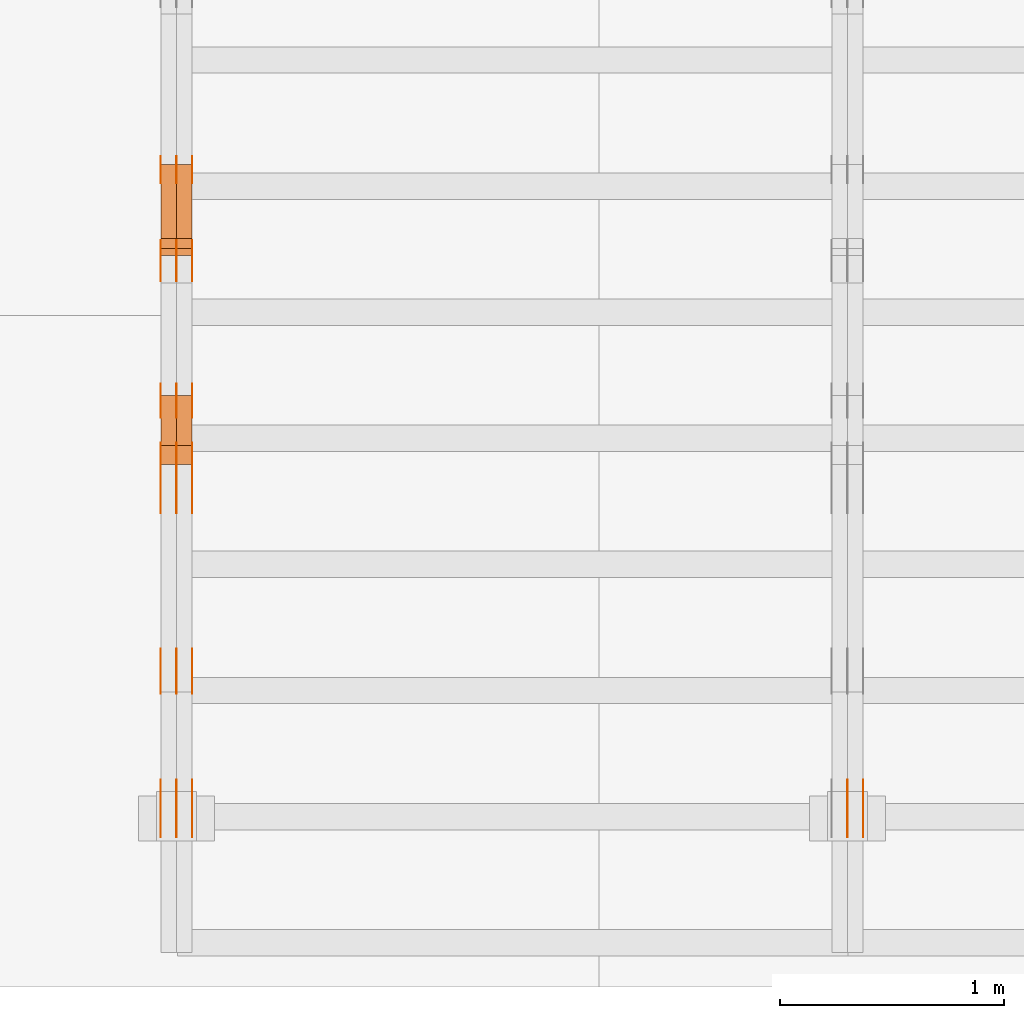
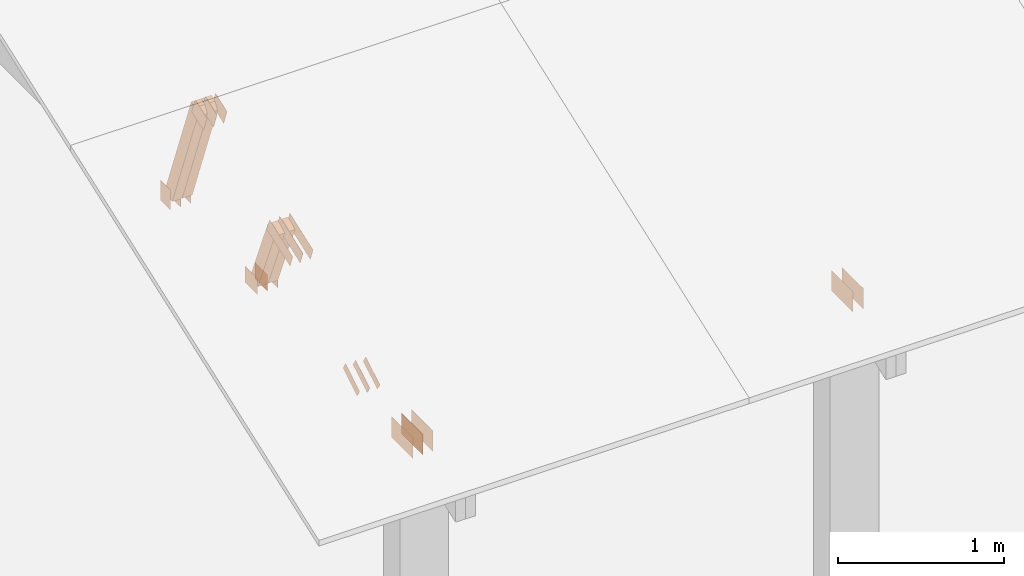
# One storey, part 67 of 189: 30 proxies.
"""IFC2X3 building model written with IfcOpenShell, lengths in millimetres."""

from ifc_helpers import new_model, entity, si_unit, converted_unit, derived_unit, direction, frame, frame_2d, origin, origin_2d_with_axis, place, context, subcontext, project, spatial, polyline, rectangle, outline, extrude, source, transform, mapped, material, type_object, type_shapes, element, save


model = new_model("IFC2X3")

# Units and contexts
model_context = context("Model", 3, precision=0.01, world=origin(), true_north=direction((6.12303176911189e-17, 1.0)))
body_context = subcontext(model_context, "Body", "Model", "MODEL_VIEW")
ifc_project = project(units=[si_unit("LENGTHUNIT", "METRE", prefix="MILLI"), si_unit("AREAUNIT", "SQUARE_METRE"), si_unit("VOLUMEUNIT", "CUBIC_METRE"), converted_unit("PLANEANGLEUNIT", "DEGREE", entity("IfcRatioMeasure", 0.0174532925199433), si_unit("PLANEANGLEUNIT", "RADIAN"), dimensions=[0, 0, 0, 0, 0, 0, 0]), si_unit("MASSUNIT", "GRAM", prefix="KILO"), derived_unit("MASSDENSITYUNIT", [(si_unit("MASSUNIT", "GRAM", prefix="KILO"), 1), (si_unit("LENGTHUNIT", "METRE"), -3)]), si_unit("TIMEUNIT", "SECOND"), si_unit("FREQUENCYUNIT", "HERTZ"), si_unit("THERMODYNAMICTEMPERATUREUNIT", "DEGREE_CELSIUS"), derived_unit("THERMALTRANSMITTANCEUNIT", [(si_unit("MASSUNIT", "GRAM", prefix="KILO"), 1), (si_unit("THERMODYNAMICTEMPERATUREUNIT", "KELVIN"), -1), (si_unit("TIMEUNIT", "SECOND"), -3)]), derived_unit("VOLUMETRICFLOWRATEUNIT", [(si_unit("LENGTHUNIT", "METRE"), 3), (si_unit("TIMEUNIT", "SECOND"), -1)]), si_unit("ELECTRICCURRENTUNIT", "AMPERE"), si_unit("ELECTRICVOLTAGEUNIT", "VOLT"), si_unit("POWERUNIT", "WATT"), si_unit("FORCEUNIT", "NEWTON"), si_unit("ILLUMINANCEUNIT", "LUX"), si_unit("LUMINOUSFLUXUNIT", "LUMEN"), si_unit("LUMINOUSINTENSITYUNIT", "CANDELA"), derived_unit("USERDEFINED", [(si_unit("MASSUNIT", "GRAM", prefix="KILO"), -1), (si_unit("LENGTHUNIT", "METRE"), -2), (si_unit("TIMEUNIT", "SECOND"), 3), (si_unit("LUMINOUSFLUXUNIT", "LUMEN"), 1)]), derived_unit("LINEARVELOCITYUNIT", [(si_unit("LENGTHUNIT", "METRE"), 1), (si_unit("TIMEUNIT", "SECOND"), -1)]), si_unit("PRESSUREUNIT", "PASCAL"), derived_unit("USERDEFINED", [(si_unit("LENGTHUNIT", "METRE"), -2), (si_unit("MASSUNIT", "GRAM", prefix="KILO"), 1), (si_unit("TIMEUNIT", "SECOND"), -2)])], contexts=[model_context])

# Site, building, storey
site_placement = place(None, origin())
site = spatial("IfcSite", under=ifc_project, at=site_placement, CompositionType="ELEMENT")
building_placement = place(site_placement, origin())
building = spatial("IfcBuilding", under=site, at=building_placement, CompositionType="ELEMENT")
storey_placement = place(building_placement, origin())
storey = spatial("IfcBuildingStorey", under=building, at=storey_placement, Name="Default", CompositionType="ELEMENT", Elevation=0.0)

# Proxies
ifc_material_1 = material(Name="IfcSurfaceStyle #22800")
building_element_proxy_type_1 = type_object("IfcBuildingElementProxyType", PredefinedType="NOTDEFINED", material=ifc_material_1)
shared_shape_1 = source(origin(), body_context, "Body", "SweptSolid", [
    extrude(rectangle(XDim=258.0, YDim=151.999992370605, at=origin_2d_with_axis()), frame((129.0, 76.0000049445079, 0.0), z_axis=(0.0, 0.0, 1.0), x_axis=(-1.0, 0.0, 0.0)), (0.0, 0.0, 1.0), 0.999999999999984),
])
type_shapes(building_element_proxy_type_1, [shared_shape_1])
proxy_1_placement = place(building_placement, frame((3336.0, 16.236328125, 268.138222870533), z_axis=(-1.0, 0.0, 0.0), x_axis=(0.0, 1.0, 0.0)))
element("IfcBuildingElementProxy", 1, at=proxy_1_placement, inside=storey, type_object=building_element_proxy_type_1, material=ifc_material_1, Name="GNT100S 152x258", context=body_context, shape_type="MappedRepresentation", body=[
    mapped(shared_shape_1, transform((0.0, 0.0, 0.0), scale=1.0)),
])
ifc_material_2 = material(Name="IfcSurfaceStyle #22743")
building_element_proxy_type_2 = type_object("IfcBuildingElementProxyType", PredefinedType="NOTDEFINED", material=ifc_material_2)
shared_shape_2 = source(origin(), body_context, "Body", "SweptSolid", [
    extrude(rectangle(XDim=258.0, YDim=151.999992370605, at=origin_2d_with_axis()), frame((129.0, 76.0000049445079, 0.0), z_axis=(0.0, 0.0, 1.0), x_axis=(-1.0, 0.0, 0.0)), (0.0, 0.0, 1.0), 0.999999999999984),
])
type_shapes(building_element_proxy_type_2, [shared_shape_2])
proxy_2_placement = place(building_placement, frame((3265.0, 16.236328125, 268.138222870533), z_axis=(-1.0, 0.0, 0.0), x_axis=(0.0, 1.0, 0.0)))
element("IfcBuildingElementProxy", 2, at=proxy_2_placement, inside=storey, type_object=building_element_proxy_type_2, material=ifc_material_2, Name="GNT100S 152x258", context=body_context, shape_type="MappedRepresentation", body=[
    mapped(shared_shape_2, transform((0.0, 0.0, 0.0), scale=1.0)),
])
ifc_material_3 = material(Name="IfcSurfaceStyle #10367")
building_element_proxy_type_3 = type_object("IfcBuildingElementProxyType", PredefinedType="NOTDEFINED", material=ifc_material_3)
shared_shape_3 = source(origin(), body_context, "Body", "SweptSolid", [
    extrude(rectangle(XDim=150.0, YDim=120.0, at=frame_2d((1.4210854715202e-14, -7.105427357601e-15), x_axis=(1.0, 0.0))), frame((75.0, 60.0004961323721, 0.0), z_axis=(0.0, 0.0, 1.0), x_axis=(-1.0, 0.0, 0.0)), (0.0, 0.0, 1.0), 1.3),
])
type_shapes(building_element_proxy_type_3, [shared_shape_3])
proxy_3_placement = place(building_placement, frame((336.3, 2940.99169136763, 170.0), z_axis=(-1.0, 0.0, 0.0), x_axis=(0.0, 0.0, 1.0)))
element("IfcBuildingElementProxy", 3, at=proxy_3_placement, inside=storey, type_object=building_element_proxy_type_3, material=ifc_material_3, context=body_context, shape_type="MappedRepresentation", body=[
    mapped(shared_shape_3, transform((0.0, 0.0, 0.0), scale=1.0)),
])
ifc_material_4 = material(Name="IfcSurfaceStyle #10310")
building_element_proxy_type_4 = type_object("IfcBuildingElementProxyType", PredefinedType="NOTDEFINED", material=ifc_material_4)
shared_shape_4 = source(origin(), body_context, "Body", "SweptSolid", [
    extrude(rectangle(XDim=150.0, YDim=120.0, at=frame_2d((1.4210854715202e-14, -7.105427357601e-15), x_axis=(1.0, 0.0))), frame((75.0, 60.0004961323721, 0.0), z_axis=(0.0, 0.0, 1.0), x_axis=(-1.0, 0.0, 0.0)), (0.0, 0.0, 1.0), 1.29999999999999),
])
type_shapes(building_element_proxy_type_4, [shared_shape_4])
proxy_4_placement = place(building_placement, frame((265.0, 2940.99169136763, 170.0), z_axis=(-1.0, 0.0, 0.0), x_axis=(0.0, 0.0, 1.0)))
element("IfcBuildingElementProxy", 4, at=proxy_4_placement, inside=storey, type_object=building_element_proxy_type_4, material=ifc_material_4, context=body_context, shape_type="MappedRepresentation", body=[
    mapped(shared_shape_4, transform((0.0, 0.0, 0.0), scale=1.0)),
])
ifc_material_5 = material(Name="IfcSurfaceStyle #10253")
building_element_proxy_type_5 = type_object("IfcBuildingElementProxyType", PredefinedType="NOTDEFINED", material=ifc_material_5)
shared_shape_5 = source(origin(), body_context, "Body", "SweptSolid", [
    extrude(rectangle(XDim=150.0, YDim=120.0, at=frame_2d((1.4210854715202e-14, -7.105427357601e-15), x_axis=(1.0, 0.0))), frame((75.0, 60.0004961323721, 0.0), z_axis=(0.0, 0.0, 1.0), x_axis=(-1.0, 0.0, 0.0)), (0.0, 0.0, 1.0), 1.29999999999999),
])
type_shapes(building_element_proxy_type_5, [shared_shape_5])
proxy_5_placement = place(building_placement, frame((266.3, 2940.99169136763, 170.0), z_axis=(-1.0, 0.0, 0.0), x_axis=(0.0, 0.0, 1.0)))
element("IfcBuildingElementProxy", 5, at=proxy_5_placement, inside=storey, type_object=building_element_proxy_type_5, material=ifc_material_5, context=body_context, shape_type="MappedRepresentation", body=[
    mapped(shared_shape_5, transform((0.0, 0.0, 0.0), scale=1.0)),
])
ifc_material_6 = material(Name="IfcSurfaceStyle #10196")
building_element_proxy_type_6 = type_object("IfcBuildingElementProxyType", PredefinedType="NOTDEFINED", material=ifc_material_6)
shared_shape_6 = source(origin(), body_context, "Body", "SweptSolid", [
    extrude(rectangle(XDim=150.0, YDim=120.0, at=frame_2d((1.4210854715202e-14, -7.105427357601e-15), x_axis=(1.0, 0.0))), frame((75.0, 60.0004961323721, 0.0), z_axis=(0.0, 0.0, 1.0), x_axis=(-1.0, 0.0, 0.0)), (0.0, 0.0, 1.0), 1.29999999999999),
])
type_shapes(building_element_proxy_type_6, [shared_shape_6])
proxy_6_placement = place(building_placement, frame((195.0, 2940.99169136763, 170.0), z_axis=(-1.0, 0.0, 0.0), x_axis=(0.0, 0.0, 1.0)))
element("IfcBuildingElementProxy", 6, at=proxy_6_placement, inside=storey, type_object=building_element_proxy_type_6, material=ifc_material_6, context=body_context, shape_type="MappedRepresentation", body=[
    mapped(shared_shape_6, transform((0.0, 0.0, 0.0), scale=1.0)),
])
ifc_material_7 = material(Name="IfcSurfaceStyle #10139")
building_element_proxy_type_7 = type_object("IfcBuildingElementProxyType", PredefinedType="NOTDEFINED", material=ifc_material_7)
shared_shape_7 = source(origin(), body_context, "Body", "SweptSolid", [
    extrude(outline(polyline([(-75.0008071857483, -59.9999039432187), (75.0002916555677, -59.9999039432187), (75.0008280609982, 59.9999039432187), (-75.0003125308176, 59.9999039432187), (-75.0008071857483, -59.9999039432187)])), frame((75.0008280609982, 60.0002349219685, 0.0), z_axis=(0.0, 0.0, 1.0), x_axis=(-1.0, 0.0, 0.0)), (0.0, 0.0, 1.0), 1.3),
])
type_shapes(building_element_proxy_type_7, [shared_shape_7])
proxy_7_placement = place(building_placement, frame((336.3, 2502.466796875, 1113.95080566406), z_axis=(-1.0, 0.0, 0.0), x_axis=(0.0, 0.939692620785908, 0.342020143325669)))
element("IfcBuildingElementProxy", 7, at=proxy_7_placement, inside=storey, type_object=building_element_proxy_type_7, material=ifc_material_7, context=body_context, shape_type="MappedRepresentation", body=[
    mapped(shared_shape_7, transform((0.0, 0.0, 0.0), scale=1.0)),
])
ifc_material_8 = material(Name="IfcSurfaceStyle #10082")
building_element_proxy_type_8 = type_object("IfcBuildingElementProxyType", PredefinedType="NOTDEFINED", material=ifc_material_8)
shared_shape_8 = source(origin(), body_context, "Body", "SweptSolid", [
    extrude(outline(polyline([(-75.0008071857483, -59.9999039432187), (75.0002916555677, -59.9999039432187), (75.0008280609982, 59.9999039432187), (-75.0003125308176, 59.9999039432187), (-75.0008071857483, -59.9999039432187)])), frame((75.0008280609982, 60.0002349219685, 0.0), z_axis=(0.0, 0.0, 1.0), x_axis=(-1.0, 0.0, 0.0)), (0.0, 0.0, 1.0), 1.29999999999999),
])
type_shapes(building_element_proxy_type_8, [shared_shape_8])
proxy_8_placement = place(building_placement, frame((265.0, 2502.466796875, 1113.95080566406), z_axis=(-1.0, 0.0, 0.0), x_axis=(0.0, 0.939692620785908, 0.342020143325669)))
element("IfcBuildingElementProxy", 8, at=proxy_8_placement, inside=storey, type_object=building_element_proxy_type_8, material=ifc_material_8, context=body_context, shape_type="MappedRepresentation", body=[
    mapped(shared_shape_8, transform((0.0, 0.0, 0.0), scale=1.0)),
])
ifc_material_9 = material(Name="IfcSurfaceStyle #10025")
building_element_proxy_type_9 = type_object("IfcBuildingElementProxyType", PredefinedType="NOTDEFINED", material=ifc_material_9)
shared_shape_9 = source(origin(), body_context, "Body", "SweptSolid", [
    extrude(outline(polyline([(-75.0008071857483, -59.9999039432187), (75.0002916555677, -59.9999039432187), (75.0008280609982, 59.9999039432187), (-75.0003125308176, 59.9999039432187), (-75.0008071857483, -59.9999039432187)])), frame((75.0008280609982, 60.0002349219685, 0.0), z_axis=(0.0, 0.0, 1.0), x_axis=(-1.0, 0.0, 0.0)), (0.0, 0.0, 1.0), 1.29999999999999),
])
type_shapes(building_element_proxy_type_9, [shared_shape_9])
proxy_9_placement = place(building_placement, frame((266.3, 2502.466796875, 1113.95080566406), z_axis=(-1.0, 0.0, 0.0), x_axis=(0.0, 0.939692620785908, 0.342020143325669)))
element("IfcBuildingElementProxy", 9, at=proxy_9_placement, inside=storey, type_object=building_element_proxy_type_9, material=ifc_material_9, context=body_context, shape_type="MappedRepresentation", body=[
    mapped(shared_shape_9, transform((0.0, 0.0, 0.0), scale=1.0)),
])
ifc_material_10 = material(Name="IfcSurfaceStyle #9968")
building_element_proxy_type_10 = type_object("IfcBuildingElementProxyType", PredefinedType="NOTDEFINED", material=ifc_material_10)
shared_shape_10 = source(origin(), body_context, "Body", "SweptSolid", [
    extrude(outline(polyline([(-75.0008071857483, -59.9999039432187), (75.0002916555677, -59.9999039432187), (75.0008280609982, 59.9999039432187), (-75.0003125308176, 59.9999039432187), (-75.0008071857483, -59.9999039432187)])), frame((75.0008280609982, 60.0002349219685, 0.0), z_axis=(0.0, 0.0, 1.0), x_axis=(-1.0, 0.0, 0.0)), (0.0, 0.0, 1.0), 1.29999999999999),
])
type_shapes(building_element_proxy_type_10, [shared_shape_10])
proxy_10_placement = place(building_placement, frame((195.0, 2502.466796875, 1113.95080566406), z_axis=(-1.0, 0.0, 0.0), x_axis=(0.0, 0.939692620785908, 0.342020143325669)))
element("IfcBuildingElementProxy", 10, at=proxy_10_placement, inside=storey, type_object=building_element_proxy_type_10, material=ifc_material_10, context=body_context, shape_type="MappedRepresentation", body=[
    mapped(shared_shape_10, transform((0.0, 0.0, 0.0), scale=1.0)),
])
ifc_material_11 = material(Name="IfcSurfaceStyle #9455")
building_element_proxy_type_11 = type_object("IfcBuildingElementProxyType", PredefinedType="NOTDEFINED", material=ifc_material_11)
shared_shape_11 = source(origin(), body_context, "Body", "SweptSolid", [
    extrude(rectangle(XDim=150.0, YDim=120.0, at=origin_2d_with_axis()), frame((75.0004757715869, 60.0, 0.0), z_axis=(0.0, 0.0, 1.0), x_axis=(-1.0, 0.0, 0.0)), (0.0, 0.0, 1.0), 1.3),
])
type_shapes(building_element_proxy_type_11, [shared_shape_11])
proxy_11_placement = place(building_placement, frame((336.3, 1892.68702422841, 305.0), z_axis=(-1.0, 0.0, 0.0), x_axis=(0.0, 1.0, 0.0)))
element("IfcBuildingElementProxy", 11, at=proxy_11_placement, inside=storey, type_object=building_element_proxy_type_11, material=ifc_material_11, context=body_context, shape_type="MappedRepresentation", body=[
    mapped(shared_shape_11, transform((0.0, 0.0, 0.0), scale=1.0)),
])
ifc_material_12 = material(Name="IfcSurfaceStyle #9398")
building_element_proxy_type_12 = type_object("IfcBuildingElementProxyType", PredefinedType="NOTDEFINED", material=ifc_material_12)
shared_shape_12 = source(origin(), body_context, "Body", "SweptSolid", [
    extrude(rectangle(XDim=150.0, YDim=120.0, at=origin_2d_with_axis()), frame((75.0004757715869, 60.0, 0.0), z_axis=(0.0, 0.0, 1.0), x_axis=(-1.0, 0.0, 0.0)), (0.0, 0.0, 1.0), 1.29999999999999),
])
type_shapes(building_element_proxy_type_12, [shared_shape_12])
proxy_12_placement = place(building_placement, frame((265.0, 1892.68702422841, 305.0), z_axis=(-1.0, 0.0, 0.0), x_axis=(0.0, 1.0, 0.0)))
element("IfcBuildingElementProxy", 12, at=proxy_12_placement, inside=storey, type_object=building_element_proxy_type_12, material=ifc_material_12, context=body_context, shape_type="MappedRepresentation", body=[
    mapped(shared_shape_12, transform((0.0, 0.0, 0.0), scale=1.0)),
])
ifc_material_13 = material(Name="IfcSurfaceStyle #9341")
building_element_proxy_type_13 = type_object("IfcBuildingElementProxyType", PredefinedType="NOTDEFINED", material=ifc_material_13)
shared_shape_13 = source(origin(), body_context, "Body", "SweptSolid", [
    extrude(rectangle(XDim=150.0, YDim=120.0, at=origin_2d_with_axis()), frame((75.0004757715869, 60.0, 0.0), z_axis=(0.0, 0.0, 1.0), x_axis=(-1.0, 0.0, 0.0)), (0.0, 0.0, 1.0), 1.29999999999999),
])
type_shapes(building_element_proxy_type_13, [shared_shape_13])
proxy_13_placement = place(building_placement, frame((266.3, 1892.68702422841, 305.0), z_axis=(-1.0, 0.0, 0.0), x_axis=(0.0, 1.0, 0.0)))
element("IfcBuildingElementProxy", 13, at=proxy_13_placement, inside=storey, type_object=building_element_proxy_type_13, material=ifc_material_13, context=body_context, shape_type="MappedRepresentation", body=[
    mapped(shared_shape_13, transform((0.0, 0.0, 0.0), scale=1.0)),
])
ifc_material_14 = material(Name="IfcSurfaceStyle #9284")
building_element_proxy_type_14 = type_object("IfcBuildingElementProxyType", PredefinedType="NOTDEFINED", material=ifc_material_14)
shared_shape_14 = source(origin(), body_context, "Body", "SweptSolid", [
    extrude(rectangle(XDim=150.0, YDim=120.0, at=origin_2d_with_axis()), frame((75.0004757715869, 60.0, 0.0), z_axis=(0.0, 0.0, 1.0), x_axis=(-1.0, 0.0, 0.0)), (0.0, 0.0, 1.0), 1.29999999999999),
])
type_shapes(building_element_proxy_type_14, [shared_shape_14])
proxy_14_placement = place(building_placement, frame((195.0, 1892.68702422841, 305.0), z_axis=(-1.0, 0.0, 0.0), x_axis=(0.0, 1.0, 0.0)))
element("IfcBuildingElementProxy", 14, at=proxy_14_placement, inside=storey, type_object=building_element_proxy_type_14, material=ifc_material_14, context=body_context, shape_type="MappedRepresentation", body=[
    mapped(shared_shape_14, transform((0.0, 0.0, 0.0), scale=1.0)),
])
ifc_material_15 = material(Name="IfcSurfaceStyle #9227")
building_element_proxy_type_15 = type_object("IfcBuildingElementProxyType", PredefinedType="NOTDEFINED", material=ifc_material_15)
shared_shape_15 = source(origin(), body_context, "Body", "SweptSolid", [
    extrude(outline(polyline([(-150.000217420008, -47.9999344162752), (150.000165800718, -47.9999344162752), (150.000227857633, 47.9999344162752), (-150.000176238343, 47.9999344162752), (-150.000217420008, -47.9999344162752)])), frame((150.000227857633, 48.0000430742566, 0.0), z_axis=(0.0, 0.0, 1.0), x_axis=(-1.0, 0.0, 0.0)), (0.0, 0.0, 1.0), 1.29999999999999),
])
type_shapes(building_element_proxy_type_15, [shared_shape_15])
proxy_15_placement = place(building_placement, frame((336.3, 1464.46484375, 723.378723144533), z_axis=(-1.0, 0.0, 0.0), x_axis=(0.0, 0.939692620785908, 0.342020143325669)))
element("IfcBuildingElementProxy", 15, at=proxy_15_placement, inside=storey, type_object=building_element_proxy_type_15, material=ifc_material_15, context=body_context, shape_type="MappedRepresentation", body=[
    mapped(shared_shape_15, transform((0.0, 0.0, 0.0), scale=1.0)),
])
ifc_material_16 = material(Name="IfcSurfaceStyle #9170")
building_element_proxy_type_16 = type_object("IfcBuildingElementProxyType", PredefinedType="NOTDEFINED", material=ifc_material_16)
shared_shape_16 = source(origin(), body_context, "Body", "SweptSolid", [
    extrude(outline(polyline([(-150.000217420008, -47.9999344162752), (150.000165800718, -47.9999344162752), (150.000227857633, 47.9999344162752), (-150.000176238343, 47.9999344162752), (-150.000217420008, -47.9999344162752)])), frame((150.000227857633, 48.0000430742566, 0.0), z_axis=(0.0, 0.0, 1.0), x_axis=(-1.0, 0.0, 0.0)), (0.0, 0.0, 1.0), 1.29999999999998),
])
type_shapes(building_element_proxy_type_16, [shared_shape_16])
proxy_16_placement = place(building_placement, frame((265.0, 1464.46484375, 723.378723144533), z_axis=(-1.0, 0.0, 0.0), x_axis=(0.0, 0.939692620785908, 0.342020143325669)))
element("IfcBuildingElementProxy", 16, at=proxy_16_placement, inside=storey, type_object=building_element_proxy_type_16, material=ifc_material_16, context=body_context, shape_type="MappedRepresentation", body=[
    mapped(shared_shape_16, transform((0.0, 0.0, 0.0), scale=1.0)),
])
ifc_material_17 = material(Name="IfcSurfaceStyle #9113")
building_element_proxy_type_17 = type_object("IfcBuildingElementProxyType", PredefinedType="NOTDEFINED", material=ifc_material_17)
shared_shape_17 = source(origin(), body_context, "Body", "SweptSolid", [
    extrude(outline(polyline([(-150.000217420008, -47.9999344162752), (150.000165800718, -47.9999344162752), (150.000227857633, 47.9999344162752), (-150.000176238343, 47.9999344162752), (-150.000217420008, -47.9999344162752)])), frame((150.000227857633, 48.0000430742566, 0.0), z_axis=(0.0, 0.0, 1.0), x_axis=(-1.0, 0.0, 0.0)), (0.0, 0.0, 1.0), 1.29999999999998),
])
type_shapes(building_element_proxy_type_17, [shared_shape_17])
proxy_17_placement = place(building_placement, frame((266.3, 1464.46484375, 723.378723144533), z_axis=(-1.0, 0.0, 0.0), x_axis=(0.0, 0.939692620785908, 0.342020143325669)))
element("IfcBuildingElementProxy", 17, at=proxy_17_placement, inside=storey, type_object=building_element_proxy_type_17, material=ifc_material_17, context=body_context, shape_type="MappedRepresentation", body=[
    mapped(shared_shape_17, transform((0.0, 0.0, 0.0), scale=1.0)),
])
ifc_material_18 = material(Name="IfcSurfaceStyle #9056")
building_element_proxy_type_18 = type_object("IfcBuildingElementProxyType", PredefinedType="NOTDEFINED", material=ifc_material_18)
shared_shape_18 = source(origin(), body_context, "Body", "SweptSolid", [
    extrude(outline(polyline([(-150.000217420008, -47.9999344162752), (150.000165800718, -47.9999344162752), (150.000227857633, 47.9999344162752), (-150.000176238343, 47.9999344162752), (-150.000217420008, -47.9999344162752)])), frame((150.000227857633, 48.0000430742566, 0.0), z_axis=(0.0, 0.0, 1.0), x_axis=(-1.0, 0.0, 0.0)), (0.0, 0.0, 1.0), 1.29999999999998),
])
type_shapes(building_element_proxy_type_18, [shared_shape_18])
proxy_18_placement = place(building_placement, frame((195.0, 1464.46484375, 723.378723144533), z_axis=(-1.0, 0.0, 0.0), x_axis=(0.0, 0.939692620785908, 0.342020143325669)))
element("IfcBuildingElementProxy", 18, at=proxy_18_placement, inside=storey, type_object=building_element_proxy_type_18, material=ifc_material_18, context=body_context, shape_type="MappedRepresentation", body=[
    mapped(shared_shape_18, transform((0.0, 0.0, 0.0), scale=1.0)),
])
ifc_material_19 = material(Name="IfcSurfaceStyle #8543")
building_element_proxy_type_19 = type_object("IfcBuildingElementProxyType", PredefinedType="NOTDEFINED", material=ifc_material_19)
shared_shape_19 = source(origin(), body_context, "Body", "SweptSolid", [
    extrude(outline(polyline([(-100.000388510424, -29.9995882393532), (100.000691805256, -29.9995882393532), (100.000392424258, 29.9995882393532), (-100.00069571909, 29.9995882393532), (-100.000388510424, -29.9995882393532)])), frame((100.000691805256, 30.0002299338894, 0.0), z_axis=(0.0, 0.0, 1.0), x_axis=(-1.0, 0.0, 0.0)), (0.0, 0.0, 1.0), 1.3),
])
type_shapes(building_element_proxy_type_19, [shared_shape_19])
proxy_19_placement = place(building_placement, frame((336.3, 656.945055513712, 219.45219322107), z_axis=(-1.0, 0.0, 0.0), x_axis=(0.0, 0.858392121304013, 0.51299411895576)))
element("IfcBuildingElementProxy", 19, at=proxy_19_placement, inside=storey, type_object=building_element_proxy_type_19, material=ifc_material_19, context=body_context, shape_type="MappedRepresentation", body=[
    mapped(shared_shape_19, transform((0.0, 0.0, 0.0), scale=1.0)),
])
ifc_material_20 = material(Name="IfcSurfaceStyle #8486")
building_element_proxy_type_20 = type_object("IfcBuildingElementProxyType", PredefinedType="NOTDEFINED", material=ifc_material_20)
shared_shape_20 = source(origin(), body_context, "Body", "SweptSolid", [
    extrude(outline(polyline([(-100.000388510424, -29.9995882393532), (100.000691805256, -29.9995882393532), (100.000392424258, 29.9995882393532), (-100.00069571909, 29.9995882393532), (-100.000388510424, -29.9995882393532)])), frame((100.000691805256, 30.0002299338894, 0.0), z_axis=(0.0, 0.0, 1.0), x_axis=(-1.0, 0.0, 0.0)), (0.0, 0.0, 1.0), 1.29999999999998),
])
type_shapes(building_element_proxy_type_20, [shared_shape_20])
proxy_20_placement = place(building_placement, frame((265.0, 656.945055513712, 219.45219322107), z_axis=(-1.0, 0.0, 0.0), x_axis=(0.0, 0.858392121304013, 0.51299411895576)))
element("IfcBuildingElementProxy", 20, at=proxy_20_placement, inside=storey, type_object=building_element_proxy_type_20, material=ifc_material_20, context=body_context, shape_type="MappedRepresentation", body=[
    mapped(shared_shape_20, transform((0.0, 0.0, 0.0), scale=1.0)),
])
ifc_material_21 = material(Name="IfcSurfaceStyle #8429")
building_element_proxy_type_21 = type_object("IfcBuildingElementProxyType", PredefinedType="NOTDEFINED", material=ifc_material_21)
shared_shape_21 = source(origin(), body_context, "Body", "SweptSolid", [
    extrude(outline(polyline([(-100.000388510424, -29.9995882393532), (100.000691805256, -29.9995882393532), (100.000392424258, 29.9995882393532), (-100.00069571909, 29.9995882393532), (-100.000388510424, -29.9995882393532)])), frame((100.000691805256, 30.0002299338894, 0.0), z_axis=(0.0, 0.0, 1.0), x_axis=(-1.0, 0.0, 0.0)), (0.0, 0.0, 1.0), 1.29999999999998),
])
type_shapes(building_element_proxy_type_21, [shared_shape_21])
proxy_21_placement = place(building_placement, frame((266.3, 656.945055513712, 219.45219322107), z_axis=(-1.0, 0.0, 0.0), x_axis=(0.0, 0.858392121304013, 0.51299411895576)))
element("IfcBuildingElementProxy", 21, at=proxy_21_placement, inside=storey, type_object=building_element_proxy_type_21, material=ifc_material_21, context=body_context, shape_type="MappedRepresentation", body=[
    mapped(shared_shape_21, transform((0.0, 0.0, 0.0), scale=1.0)),
])
ifc_material_22 = material(Name="IfcSurfaceStyle #8372")
building_element_proxy_type_22 = type_object("IfcBuildingElementProxyType", PredefinedType="NOTDEFINED", material=ifc_material_22)
shared_shape_22 = source(origin(), body_context, "Body", "SweptSolid", [
    extrude(outline(polyline([(-100.000388510424, -29.9995882393532), (100.000691805256, -29.9995882393532), (100.000392424258, 29.9995882393532), (-100.00069571909, 29.9995882393532), (-100.000388510424, -29.9995882393532)])), frame((100.000691805256, 30.0002299338894, 0.0), z_axis=(0.0, 0.0, 1.0), x_axis=(-1.0, 0.0, 0.0)), (0.0, 0.0, 1.0), 1.29999999999999),
])
type_shapes(building_element_proxy_type_22, [shared_shape_22])
proxy_22_placement = place(building_placement, frame((195.0, 656.945055513712, 219.45219322107), z_axis=(-1.0, 0.0, 0.0), x_axis=(0.0, 0.858392121304013, 0.51299411895576)))
element("IfcBuildingElementProxy", 22, at=proxy_22_placement, inside=storey, type_object=building_element_proxy_type_22, material=ifc_material_22, context=body_context, shape_type="MappedRepresentation", body=[
    mapped(shared_shape_22, transform((0.0, 0.0, 0.0), scale=1.0)),
])
ifc_material_23 = material(Name="IfcSurfaceStyle #7007")
building_element_proxy_type_23 = type_object("IfcBuildingElementProxyType", PredefinedType="NOTDEFINED", material=ifc_material_23)
shared_shape_23 = source(origin(), body_context, "Body", "SweptSolid", [
    extrude(rectangle(XDim=258.0, YDim=151.999992370605, at=origin_2d_with_axis()), frame((129.0, 76.0000049445079, 0.0), z_axis=(0.0, 0.0, 1.0), x_axis=(-1.0, 0.0, 0.0)), (0.0, 0.0, 1.0), 0.999999999999984),
])
type_shapes(building_element_proxy_type_23, [shared_shape_23])
proxy_23_placement = place(building_placement, frame((336.0, 16.236328125, 268.138222870533), z_axis=(-1.0, 0.0, 0.0), x_axis=(0.0, 1.0, 0.0)))
element("IfcBuildingElementProxy", 23, at=proxy_23_placement, inside=storey, type_object=building_element_proxy_type_23, material=ifc_material_23, Name="GNT100S 152x258", context=body_context, shape_type="MappedRepresentation", body=[
    mapped(shared_shape_23, transform((0.0, 0.0, 0.0), scale=1.0)),
])
ifc_material_24 = material(Name="IfcSurfaceStyle #6950")
building_element_proxy_type_24 = type_object("IfcBuildingElementProxyType", PredefinedType="NOTDEFINED", material=ifc_material_24)
shared_shape_24 = source(origin(), body_context, "Body", "SweptSolid", [
    extrude(rectangle(XDim=258.0, YDim=151.999992370605, at=origin_2d_with_axis()), frame((129.0, 76.0000049445079, 0.0), z_axis=(0.0, 0.0, 1.0), x_axis=(-1.0, 0.0, 0.0)), (0.0, 0.0, 1.0), 0.999999999999984),
])
type_shapes(building_element_proxy_type_24, [shared_shape_24])
proxy_24_placement = place(building_placement, frame((265.0, 16.236328125, 268.138222870533), z_axis=(-1.0, 0.0, 0.0), x_axis=(0.0, 1.0, 0.0)))
element("IfcBuildingElementProxy", 24, at=proxy_24_placement, inside=storey, type_object=building_element_proxy_type_24, material=ifc_material_24, Name="GNT100S 152x258", context=body_context, shape_type="MappedRepresentation", body=[
    mapped(shared_shape_24, transform((0.0, 0.0, 0.0), scale=1.0)),
])
ifc_material_25 = material(Name="IfcSurfaceStyle #6893")
building_element_proxy_type_25 = type_object("IfcBuildingElementProxyType", PredefinedType="NOTDEFINED", material=ifc_material_25)
shared_shape_25 = source(origin(), body_context, "Body", "SweptSolid", [
    extrude(rectangle(XDim=258.0, YDim=151.999992370605, at=origin_2d_with_axis()), frame((129.0, 76.0000049445079, 0.0), z_axis=(0.0, 0.0, 1.0), x_axis=(-1.0, 0.0, 0.0)), (0.0, 0.0, 1.0), 0.999999999999984),
])
type_shapes(building_element_proxy_type_25, [shared_shape_25])
proxy_25_placement = place(building_placement, frame((266.0, 16.236328125, 268.138222870533), z_axis=(-1.0, 0.0, 0.0), x_axis=(0.0, 1.0, 0.0)))
element("IfcBuildingElementProxy", 25, at=proxy_25_placement, inside=storey, type_object=building_element_proxy_type_25, material=ifc_material_25, Name="GNT100S 152x258", context=body_context, shape_type="MappedRepresentation", body=[
    mapped(shared_shape_25, transform((0.0, 0.0, 0.0), scale=1.0)),
])
ifc_material_26 = material(Name="IfcSurfaceStyle #6836")
building_element_proxy_type_26 = type_object("IfcBuildingElementProxyType", PredefinedType="NOTDEFINED", material=ifc_material_26)
shared_shape_26 = source(origin(), body_context, "Body", "SweptSolid", [
    extrude(rectangle(XDim=258.0, YDim=151.999992370605, at=origin_2d_with_axis()), frame((129.0, 76.0000049445079, 0.0), z_axis=(0.0, 0.0, 1.0), x_axis=(-1.0, 0.0, 0.0)), (0.0, 0.0, 1.0), 0.999999999999984),
])
type_shapes(building_element_proxy_type_26, [shared_shape_26])
proxy_26_placement = place(building_placement, frame((195.0, 16.236328125, 268.138222870533), z_axis=(-1.0, 0.0, 0.0), x_axis=(0.0, 1.0, 0.0)))
element("IfcBuildingElementProxy", 26, at=proxy_26_placement, inside=storey, type_object=building_element_proxy_type_26, material=ifc_material_26, Name="GNT100S 152x258", context=body_context, shape_type="MappedRepresentation", body=[
    mapped(shared_shape_26, transform((0.0, 0.0, 0.0), scale=1.0)),
])
ifc_material_27 = material(Name="IfcSurfaceStyle #2567")
building_element_proxy_type_27 = type_object("IfcBuildingElementProxyType", Name="T1-W14 2565", PredefinedType="NOTDEFINED", material=ifc_material_27)
shared_shape_27 = source(origin(), body_context, "Body", "SweptSolid", [
    extrude(outline(polyline([(-526.068269984593, -47.5004595774917), (341.27769108205, -47.5004595774917), (373.679499344758, 0.000392511719837607), (373.092506900368, 47.5002633216318), (-561.981427342584, 47.5002633216318), (-526.068269984593, -47.5004595774917)])), frame((373.67978783425, 47.5005221796964, 0.0), z_axis=(0.0, 0.0, 1.0), x_axis=(-1.0, 0.0, 0.0)), (0.0, 0.0, 1.0), 69.9999999999999),
])
type_shapes(building_element_proxy_type_27, [shared_shape_27])
proxy_27_placement = place(building_placement, frame((335.0, 2693.38241954499, 1120.21215048788), z_axis=(-1.0, 0.0, 0.0), x_axis=(0.0, 0.353606472447916, -0.935394281916958)))
element("IfcBuildingElementProxy", 27, at=proxy_27_placement, inside=storey, type_object=building_element_proxy_type_27, material=ifc_material_27, Name="T1-W14", context=body_context, shape_type="MappedRepresentation", body=[
    mapped(shared_shape_27, transform((0.0, 0.0, 0.0), scale=1.0)),
])
ifc_material_28 = material(Name="IfcSurfaceStyle #2501")
building_element_proxy_type_28 = type_object("IfcBuildingElementProxyType", Name="T1-W14 2499", PredefinedType="NOTDEFINED", material=ifc_material_28)
shared_shape_28 = source(origin(), body_context, "Body", "SweptSolid", [
    extrude(outline(polyline([(-526.068269984593, -47.5004595774917), (341.27769108205, -47.5004595774917), (373.679499344758, 0.000392511719837607), (373.092506900368, 47.5002633216318), (-561.981427342584, 47.5002633216318), (-526.068269984593, -47.5004595774917)])), frame((373.67978783425, 47.5005221796964, 0.0), z_axis=(0.0, 0.0, 1.0), x_axis=(-1.0, 0.0, 0.0)), (0.0, 0.0, 1.0), 69.9999999999999),
])
type_shapes(building_element_proxy_type_28, [shared_shape_28])
proxy_28_placement = place(building_placement, frame((265.0, 2693.38241954499, 1120.21215048788), z_axis=(-1.0, 0.0, 0.0), x_axis=(0.0, 0.353606472447916, -0.935394281916958)))
element("IfcBuildingElementProxy", 28, at=proxy_28_placement, inside=storey, type_object=building_element_proxy_type_28, material=ifc_material_28, Name="T1-W14", context=body_context, shape_type="MappedRepresentation", body=[
    mapped(shared_shape_28, transform((0.0, 0.0, 0.0), scale=1.0)),
])
ifc_material_29 = material(Name="IfcSurfaceStyle #2039")
building_element_proxy_type_29 = type_object("IfcBuildingElementProxyType", Name="T1-W15 2037", PredefinedType="NOTDEFINED", material=ifc_material_29)
shared_shape_29 = source(origin(), body_context, "Body", "SweptSolid", [
    extrude(outline(polyline([(-317.132720418368, -47.5005147440206), (220.445242566881, -47.5005147440206), (227.5021778825, -0.000126286009697951), (225.500088907744, 47.5005778870255), (-356.314788938758, 47.5005778870255), (-317.132720418368, -47.5005147440206)])), frame((227.5021778825, 47.5005778870255, 0.0), z_axis=(0.0, 0.0, 1.0), x_axis=(-1.0, 0.0, 0.0)), (0.0, 0.0, 1.0), 70.0),
])
type_shapes(building_element_proxy_type_29, [shared_shape_29])
proxy_29_placement = place(building_placement, frame((335.0, 1767.47882447529, 784.714556181707), z_axis=(-1.0, 0.0, 0.0), x_axis=(0.0, 0.381283266795389, -0.924458257825542)))
element("IfcBuildingElementProxy", 29, at=proxy_29_placement, inside=storey, type_object=building_element_proxy_type_29, material=ifc_material_29, Name="T1-W15", context=body_context, shape_type="MappedRepresentation", body=[
    mapped(shared_shape_29, transform((0.0, 0.0, 0.0), scale=1.0)),
])
ifc_material_30 = material(Name="IfcSurfaceStyle #1973")
building_element_proxy_type_30 = type_object("IfcBuildingElementProxyType", Name="T1-W15 1971", PredefinedType="NOTDEFINED", material=ifc_material_30)
shared_shape_30 = source(origin(), body_context, "Body", "SweptSolid", [
    extrude(outline(polyline([(-317.132720418368, -47.5005147440206), (220.445242566881, -47.5005147440206), (227.5021778825, -0.000126286009697951), (225.500088907744, 47.5005778870255), (-356.314788938758, 47.5005778870255), (-317.132720418368, -47.5005147440206)])), frame((227.5021778825, 47.5005778870255, 0.0), z_axis=(0.0, 0.0, 1.0), x_axis=(-1.0, 0.0, 0.0)), (0.0, 0.0, 1.0), 70.0),
])
type_shapes(building_element_proxy_type_30, [shared_shape_30])
proxy_30_placement = place(building_placement, frame((265.0, 1767.47882447529, 784.714556181707), z_axis=(-1.0, 0.0, 0.0), x_axis=(0.0, 0.381283266795389, -0.924458257825542)))
element("IfcBuildingElementProxy", 30, at=proxy_30_placement, inside=storey, type_object=building_element_proxy_type_30, material=ifc_material_30, Name="T1-W15", context=body_context, shape_type="MappedRepresentation", body=[
    mapped(shared_shape_30, transform((0.0, 0.0, 0.0), scale=1.0)),
])

save(model, "model.ifc")
